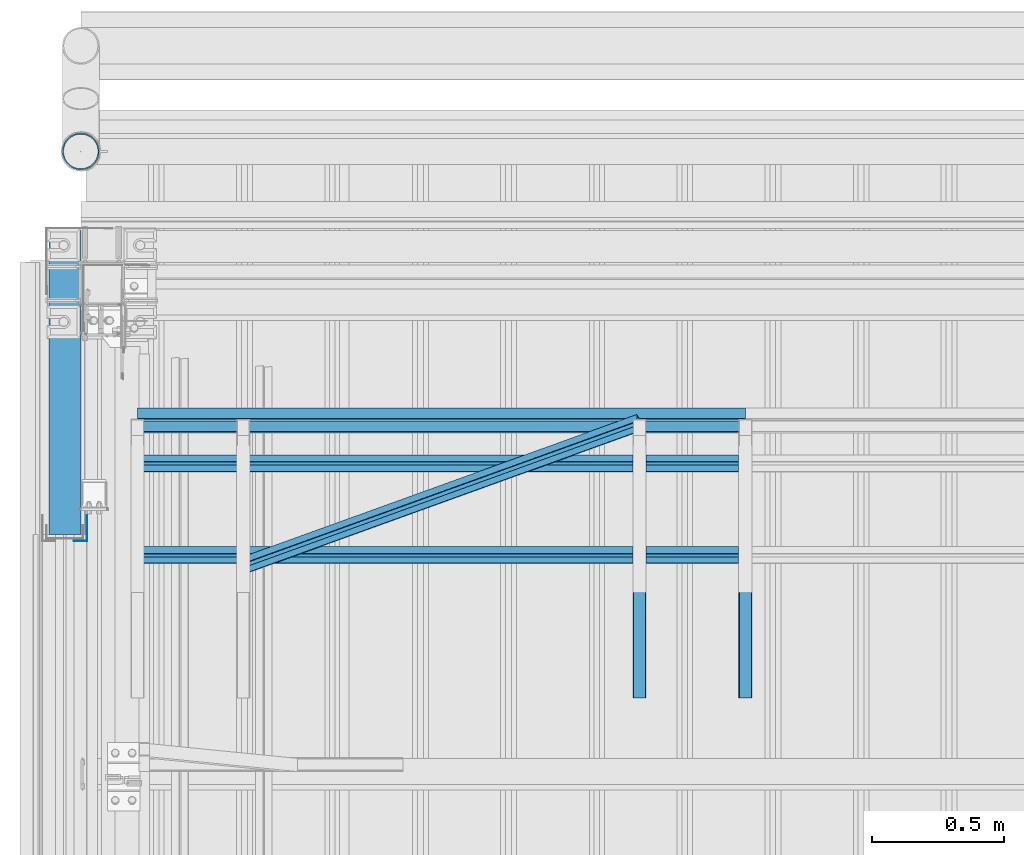
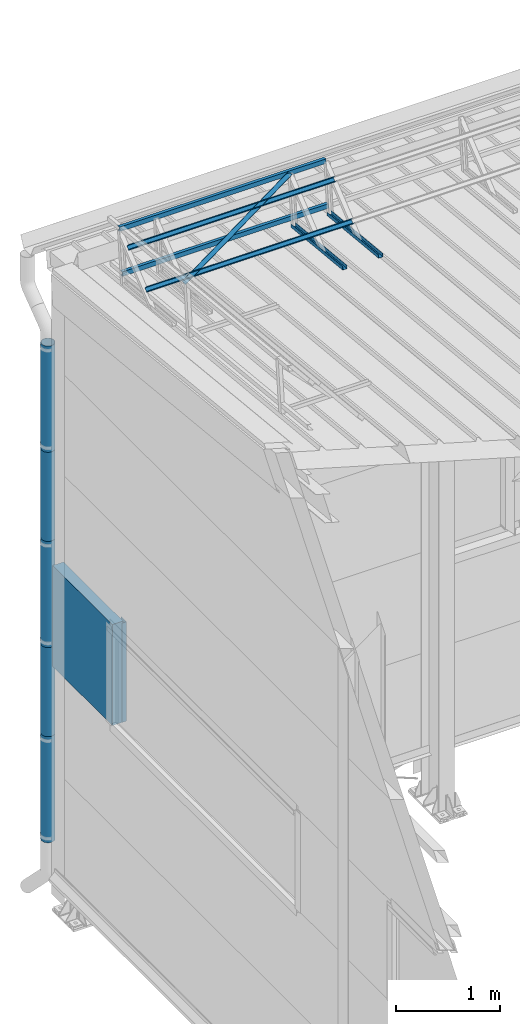
# One storey, part 51 of 709: 14 beams, 14 elements without a shape of their own.
"""IFC4 building model written with IfcOpenShell, lengths in millimetres."""

from ifc_helpers import new_model, si_unit, direction, frame, origin_with_axes, place, context, subcontext, project, spatial, line, indexed_curve, outline, extrude, material, element, aggregate, save


model = new_model("IFC4")

# Units and contexts
model_context = context("Model", 3, precision=0.2, world=origin_with_axes(), true_north=direction((0.0, 1.0)))
body_context = subcontext(model_context, "Body", "Model", "MODEL_VIEW")
ifc_project = project(units=[si_unit("LENGTHUNIT", "METRE", prefix="MILLI"), si_unit("AREAUNIT", "SQUARE_METRE"), si_unit("VOLUMEUNIT", "CUBIC_METRE"), si_unit("MASSUNIT", "GRAM", prefix="KILO"), si_unit("TIMEUNIT", "SECOND"), si_unit("PLANEANGLEUNIT", "RADIAN"), si_unit("SOLIDANGLEUNIT", "STERADIAN"), si_unit("THERMODYNAMICTEMPERATUREUNIT", "DEGREE_CELSIUS"), si_unit("LUMINOUSINTENSITYUNIT", "LUMEN")], contexts=[model_context])

# Site, building, storey
site_placement = place(None, origin_with_axes())
site = spatial("IfcSite", under=ifc_project, at=site_placement, CompositionType="ELEMENT")
building_placement = place(site_placement, origin_with_axes())
building = spatial("IfcBuilding", under=site, at=building_placement, Name="Undefined", CompositionType="ELEMENT")
storey_placement = place(building_placement, origin_with_axes())
storey = spatial("IfcBuildingStorey", under=building, at=storey_placement, Name="Undefined", CompositionType="ELEMENT", Elevation=0.0)

# Assembly, beam
assembly_1_placement = place(storey_placement, frame((2515.0, 21349.29926, 7565.33969), z_axis=(0.0, 0.099503719, 0.9950371902), x_axis=(0.0, -0.9950371902, 0.099503719)))
assembly_1 = element("IfcElementAssembly", 1, at=assembly_1_placement, inside=storey)
ifc_material_1 = material(Name="Steel_Undefined", Category="STEEL")
beam_1_placement = place(assembly_1_placement, origin_with_axes())
beam_1 = element("IfcBeam", 2, at=beam_1_placement, material=ifc_material_1, ObjectType="601", context=body_context, shape_type="SolidModel", body=[
    extrude(outline(indexed_curve([(-20.0, -25.0), (20.0, -25.0), (20.0, -22.5), (-17.5, -22.5), (-17.5, 22.5), (20.0, 22.5), (20.0, 25.0), (-20.0, 25.0)], segments=[line(1, 2, 3, 4, 5, 6, 7, 8, 1)])), frame((0.0, 0.0, 0.0), z_axis=(-1.0, 0.0, 0.0), x_axis=(0.0, 0.0, 1.0)), (0.0, 0.0, -1.0), 1000.0),
])
aggregate(assembly_1, [beam_1])

assembly_2_placement = place(storey_placement, frame((2115.0, 21349.29926, 7565.33969), z_axis=(0.0, 0.099503719, 0.9950371902), x_axis=(0.0, -0.9950371902, 0.099503719)))
assembly_2 = element("IfcElementAssembly", 3, at=assembly_2_placement, inside=storey)
beam_2_placement = place(assembly_2_placement, origin_with_axes())
beam_2 = element("IfcBeam", 4, at=beam_2_placement, material=ifc_material_1, ObjectType="601", context=body_context, shape_type="SolidModel", body=[
    extrude(outline(indexed_curve([(-20.0, -25.0), (20.0, -25.0), (20.0, -22.5), (-17.5, -22.5), (-17.5, 22.5), (20.0, 22.5), (20.0, 25.0), (-20.0, 25.0)], segments=[line(1, 2, 3, 4, 5, 6, 7, 8, 1)])), frame((0.0, 0.0, 0.0), z_axis=(-1.0, 0.0, 0.0), x_axis=(0.0, 0.0, 1.0)), (0.0, 0.0, -1.0), 1000.0),
])
aggregate(assembly_2, [beam_2])

assembly_3_placement = place(storey_placement, frame((2515.0, 21426.91216, 8140.47118), z_axis=(0.0, 0.9950371902, -0.099503719), x_axis=(-1.0, 0.0, 0.0)))
assembly_3 = element("IfcElementAssembly", 5, at=assembly_3_placement, inside=storey)
beam_3_placement = place(assembly_3_placement, origin_with_axes())
beam_3 = element("IfcBeam", 6, at=beam_3_placement, material=ifc_material_1, ObjectType="607", context=body_context, shape_type="SolidModel", body=[
    extrude(outline(indexed_curve([(-20.0, -25.0), (20.0, -25.0), (20.0, -22.5), (-17.5, -22.5), (-17.5, 22.5), (20.0, 22.5), (20.0, 25.0), (-20.0, 25.0)], segments=[line(1, 2, 3, 4, 5, 6, 7, 8, 1)])), frame((0.0, 0.0, 0.0), z_axis=(-1.0, 0.0, 0.0), x_axis=(0.0, 0.0, 1.0)), (0.0, 0.0, -1.0), 2300.0),
])
aggregate(assembly_3, [beam_3])

assembly_4_placement = place(storey_placement, frame((2515.0, 21377.1603, 7642.95259), z_axis=(0.0, 0.9950371902, -0.099503719), x_axis=(-1.0, 0.0, 0.0)))
assembly_4 = element("IfcElementAssembly", 7, at=assembly_4_placement, inside=storey)
beam_4_placement = place(assembly_4_placement, origin_with_axes())
beam_4 = element("IfcBeam", 8, at=beam_4_placement, material=ifc_material_1, ObjectType="607", context=body_context, shape_type="SolidModel", body=[
    extrude(outline(indexed_curve([(-20.0, -25.0), (20.0, -25.0), (20.0, -22.5), (-17.5, -22.5), (-17.5, 22.5), (20.0, 22.5), (20.0, 25.0), (-20.0, 25.0)], segments=[line(1, 2, 3, 4, 5, 6, 7, 8, 1)])), frame((0.0, 0.0, 0.0), z_axis=(-1.0, 0.0, 0.0), x_axis=(0.0, 0.0, 1.0)), (0.0, 0.0, -1.0), 2300.0),
])
aggregate(assembly_4, [beam_4])

assembly_5_placement = place(storey_placement, frame((2515.0, 21239.5552, 8031.29285), z_axis=(0.0, -0.6332377902, 0.7739572992), x_axis=(-1.0, 0.0, 0.0)))
assembly_5 = element("IfcElementAssembly", 9, at=assembly_5_placement, inside=storey)
beam_5_placement = place(assembly_5_placement, origin_with_axes())
beam_5 = element("IfcBeam", 10, at=beam_5_placement, material=ifc_material_1, ObjectType="607", context=body_context, shape_type="SolidModel", body=[
    extrude(outline(indexed_curve([(-20.0, -25.0), (20.0, -25.0), (20.0, -22.5), (-17.5, -22.5), (-17.5, 22.5), (20.0, 22.5), (20.0, 25.0), (-20.0, 25.0)], segments=[line(1, 2, 3, 4, 5, 6, 7, 8, 1)])), frame((0.0, 0.0, 0.0), z_axis=(-1.0, 0.0, 0.0), x_axis=(0.0, 0.0, 1.0)), (0.0, 0.0, -1.0), 2300.0),
])
aggregate(assembly_5, [beam_5])

assembly_6_placement = place(storey_placement, frame((2515.0, 20892.41357, 7747.26788), z_axis=(0.0, -0.6332377902, 0.7739572992), x_axis=(-1.0, 0.0, 0.0)))
assembly_6 = element("IfcElementAssembly", 11, at=assembly_6_placement, inside=storey)
beam_6_placement = place(assembly_6_placement, origin_with_axes())
beam_6 = element("IfcBeam", 12, at=beam_6_placement, material=ifc_material_1, ObjectType="607", context=body_context, shape_type="SolidModel", body=[
    extrude(outline(indexed_curve([(-20.0, -25.0), (20.0, -25.0), (20.0, -22.5), (-17.5, -22.5), (-17.5, 22.5), (20.0, 22.5), (20.0, 25.0), (-20.0, 25.0)], segments=[line(1, 2, 3, 4, 5, 6, 7, 8, 1)])), frame((0.0, 0.0, 0.0), z_axis=(-1.0, 0.0, 0.0), x_axis=(0.0, 0.0, 1.0)), (0.0, 0.0, -1.0), 2300.0),
])
aggregate(assembly_6, [beam_6])

assembly_7_placement = place(storey_placement, frame((2115.0, 21394.34666, 8157.9404), z_axis=(0.0, -0.6332377902, 0.7739572992), x_axis=(-0.9061831398, -0.3272952929, -0.2677870579)))
assembly_7 = element("IfcElementAssembly", 13, at=assembly_7_placement, inside=storey)
beam_7_placement = place(assembly_7_placement, origin_with_axes())
beam_7 = element("IfcBeam", 14, at=beam_7_placement, material=ifc_material_1, ObjectType="605", context=body_context, shape_type="SolidModel", body=[
    extrude(outline(indexed_curve([(-20.0, -25.0), (20.0, -25.0), (20.0, -22.5), (-17.5, -22.5), (-17.5, 22.5), (20.0, 22.5), (20.0, 25.0), (-20.0, 25.0)], segments=[line(1, 2, 3, 4, 5, 6, 7, 8, 1)])), frame((0.0, 0.0, 0.0), z_axis=(-1.0, 0.0, 0.0), x_axis=(0.0, 0.0, 1.0)), (0.0, 0.0, -1.0), 1655.29454),
])
aggregate(assembly_7, [beam_7])

assembly_8_placement = place(storey_placement, frame((0.0, 22420.0, 6276.92297), z_axis=(0.0, -1.0, 0.0), x_axis=(0.0, 0.0, -1.0)))
assembly_8 = element("IfcElementAssembly", 15, at=assembly_8_placement, inside=storey)
beam_8_placement = place(assembly_8_placement, origin_with_axes())
beam_8 = element("IfcBeam", 16, at=beam_8_placement, material=ifc_material_1, ObjectType="614", context=body_context, shape_type="SolidModel", body=[
    extrude(outline(indexed_curve([(70.0, 0.0), (69.61653, 7.31699), (68.47033, 14.55382), (66.57396, 21.63119), (63.94818, 28.47157), (60.62178, 35.0), (56.63119, 41.14497), (52.02014, 46.83914), (46.83914, 52.02014), (41.14497, 56.63119), (35.0, 60.62178), (28.47157, 63.94818), (21.63119, 66.57396), (14.55382, 68.47033), (7.31699, 69.61653), (0.0, 70.0), (-7.31699, 69.61653), (-14.55382, 68.47033), (-21.63119, 66.57396), (-28.47157, 63.94818), (-35.0, 60.62178), (-41.14497, 56.63119), (-46.83914, 52.02014), (-52.02014, 46.83914), (-56.63119, 41.14497), (-60.62178, 35.0), (-63.94818, 28.47157), (-66.57396, 21.63119), (-68.47033, 14.55382), (-69.61653, 7.31699), (-70.0, 0.0), (-69.61653, -7.31699), (-68.47033, -14.55382), (-66.57396, -21.63119), (-63.94818, -28.47157), (-60.62178, -35.0), (-56.63119, -41.14497), (-52.02014, -46.83914), (-46.83914, -52.02014), (-41.14497, -56.63119), (-35.0, -60.62178), (-28.47157, -63.94818), (-21.63119, -66.57396), (-14.55382, -68.47033), (-7.31699, -69.61653), (0.0, -70.0), (7.31699, -69.61653), (14.55382, -68.47033), (21.63119, -66.57396), (28.47157, -63.94818), (35.0, -60.62178), (41.14497, -56.63119), (46.83914, -52.02014), (52.02014, -46.83914), (56.63119, -41.14497), (60.62178, -35.0), (63.94818, -28.47157), (66.57396, -21.63119), (68.47033, -14.55382), (69.61653, -7.31699)], segments=[line(1, 2, 3, 4, 5, 6, 7, 8, 9, 10, 11, 12, 13, 14, 15, 16, 17, 18, 19, 20, 21, 22, 23, 24, 25, 26, 27, 28, 29, 30, 31, 32, 33, 34, 35, 36, 37, 38, 39, 40, 41, 42, 43, 44, 45, 46, 47, 48, 49, 50, 51, 52, 53, 54, 55, 56, 57, 58, 59, 60, 1)]), holes=[indexed_curve([(65.0, 0.0), (64.64392, -6.79435), (63.57959, -13.51426), (61.81867, -20.0861), (59.38045, -26.43788), (56.29165, -32.5), (52.5861, -38.20604), (48.30441, -43.49349), (43.49349, -48.30441), (38.20604, -52.5861), (32.5, -56.29165), (26.43788, -59.38045), (20.0861, -61.81867), (13.51426, -63.57959), (6.79435, -64.64392), (0.0, -65.0), (-6.79435, -64.64392), (-13.51426, -63.57959), (-20.0861, -61.81867), (-26.43788, -59.38045), (-32.5, -56.29165), (-38.20604, -52.5861), (-43.49349, -48.30441), (-48.30441, -43.49349), (-52.5861, -38.20604), (-56.29165, -32.5), (-59.38045, -26.43788), (-61.81867, -20.0861), (-63.57959, -13.51426), (-64.64392, -6.79435), (-65.0, 0.0), (-64.64392, 6.79435), (-63.57959, 13.51426), (-61.81867, 20.0861), (-59.38045, 26.43788), (-56.29165, 32.5), (-52.5861, 38.20604), (-48.30441, 43.49349), (-43.49349, 48.30441), (-38.20604, 52.5861), (-32.5, 56.29165), (-26.43788, 59.38045), (-20.0861, 61.81867), (-13.51426, 63.57959), (-6.79435, 64.64392), (0.0, 65.0), (6.79435, 64.64392), (13.51426, 63.57959), (20.0861, 61.81867), (26.43788, 59.38045), (32.5, 56.29165), (38.20604, 52.5861), (43.49349, 48.30441), (48.30441, 43.49349), (52.5861, 38.20604), (56.29165, 32.5), (59.38045, 26.43788), (61.81867, 20.0861), (63.57959, 13.51426), (64.64392, 6.79435)], segments=[line(1, 2, 3, 4, 5, 6, 7, 8, 9, 10, 11, 12, 13, 14, 15, 16, 17, 18, 19, 20, 21, 22, 23, 24, 25, 26, 27, 28, 29, 30, 31, 32, 33, 34, 35, 36, 37, 38, 39, 40, 41, 42, 43, 44, 45, 46, 47, 48, 49, 50, 51, 52, 53, 54, 55, 56, 57, 58, 59, 60, 1)])]), frame((0.0, 0.0, 0.0), z_axis=(-1.0, 0.0, 0.0), x_axis=(0.0, 0.0, 1.0)), (0.0, 0.0, -1.0), 1250.0),
])
aggregate(assembly_8, [beam_8])

assembly_9_placement = place(storey_placement, frame((0.0, 22420.0, 5126.92297), z_axis=(0.0, -1.0, 0.0), x_axis=(0.0, 0.0, -1.0)))
assembly_9 = element("IfcElementAssembly", 17, at=assembly_9_placement, inside=storey)
beam_9_placement = place(assembly_9_placement, origin_with_axes())
beam_9 = element("IfcBeam", 18, at=beam_9_placement, material=ifc_material_1, ObjectType="614", context=body_context, shape_type="SolidModel", body=[
    extrude(outline(indexed_curve([(70.0, 0.0), (69.61653, 7.31699), (68.47033, 14.55382), (66.57396, 21.63119), (63.94818, 28.47157), (60.62178, 35.0), (56.63119, 41.14497), (52.02014, 46.83914), (46.83914, 52.02014), (41.14497, 56.63119), (35.0, 60.62178), (28.47157, 63.94818), (21.63119, 66.57396), (14.55382, 68.47033), (7.31699, 69.61653), (0.0, 70.0), (-7.31699, 69.61653), (-14.55382, 68.47033), (-21.63119, 66.57396), (-28.47157, 63.94818), (-35.0, 60.62178), (-41.14497, 56.63119), (-46.83914, 52.02014), (-52.02014, 46.83914), (-56.63119, 41.14497), (-60.62178, 35.0), (-63.94818, 28.47157), (-66.57396, 21.63119), (-68.47033, 14.55382), (-69.61653, 7.31699), (-70.0, 0.0), (-69.61653, -7.31699), (-68.47033, -14.55382), (-66.57396, -21.63119), (-63.94818, -28.47157), (-60.62178, -35.0), (-56.63119, -41.14497), (-52.02014, -46.83914), (-46.83914, -52.02014), (-41.14497, -56.63119), (-35.0, -60.62178), (-28.47157, -63.94818), (-21.63119, -66.57396), (-14.55382, -68.47033), (-7.31699, -69.61653), (0.0, -70.0), (7.31699, -69.61653), (14.55382, -68.47033), (21.63119, -66.57396), (28.47157, -63.94818), (35.0, -60.62178), (41.14497, -56.63119), (46.83914, -52.02014), (52.02014, -46.83914), (56.63119, -41.14497), (60.62178, -35.0), (63.94818, -28.47157), (66.57396, -21.63119), (68.47033, -14.55382), (69.61653, -7.31699)], segments=[line(1, 2, 3, 4, 5, 6, 7, 8, 9, 10, 11, 12, 13, 14, 15, 16, 17, 18, 19, 20, 21, 22, 23, 24, 25, 26, 27, 28, 29, 30, 31, 32, 33, 34, 35, 36, 37, 38, 39, 40, 41, 42, 43, 44, 45, 46, 47, 48, 49, 50, 51, 52, 53, 54, 55, 56, 57, 58, 59, 60, 1)]), holes=[indexed_curve([(65.0, 0.0), (64.64392, -6.79435), (63.57959, -13.51426), (61.81867, -20.0861), (59.38045, -26.43788), (56.29165, -32.5), (52.5861, -38.20604), (48.30441, -43.49349), (43.49349, -48.30441), (38.20604, -52.5861), (32.5, -56.29165), (26.43788, -59.38045), (20.0861, -61.81867), (13.51426, -63.57959), (6.79435, -64.64392), (0.0, -65.0), (-6.79435, -64.64392), (-13.51426, -63.57959), (-20.0861, -61.81867), (-26.43788, -59.38045), (-32.5, -56.29165), (-38.20604, -52.5861), (-43.49349, -48.30441), (-48.30441, -43.49349), (-52.5861, -38.20604), (-56.29165, -32.5), (-59.38045, -26.43788), (-61.81867, -20.0861), (-63.57959, -13.51426), (-64.64392, -6.79435), (-65.0, 0.0), (-64.64392, 6.79435), (-63.57959, 13.51426), (-61.81867, 20.0861), (-59.38045, 26.43788), (-56.29165, 32.5), (-52.5861, 38.20604), (-48.30441, 43.49349), (-43.49349, 48.30441), (-38.20604, 52.5861), (-32.5, 56.29165), (-26.43788, 59.38045), (-20.0861, 61.81867), (-13.51426, 63.57959), (-6.79435, 64.64392), (0.0, 65.0), (6.79435, 64.64392), (13.51426, 63.57959), (20.0861, 61.81867), (26.43788, 59.38045), (32.5, 56.29165), (38.20604, 52.5861), (43.49349, 48.30441), (48.30441, 43.49349), (52.5861, 38.20604), (56.29165, 32.5), (59.38045, 26.43788), (61.81867, 20.0861), (63.57959, 13.51426), (64.64392, 6.79435)], segments=[line(1, 2, 3, 4, 5, 6, 7, 8, 9, 10, 11, 12, 13, 14, 15, 16, 17, 18, 19, 20, 21, 22, 23, 24, 25, 26, 27, 28, 29, 30, 31, 32, 33, 34, 35, 36, 37, 38, 39, 40, 41, 42, 43, 44, 45, 46, 47, 48, 49, 50, 51, 52, 53, 54, 55, 56, 57, 58, 59, 60, 1)])]), frame((0.0, 0.0, 0.0), z_axis=(-1.0, 0.0, 0.0), x_axis=(0.0, 0.0, 1.0)), (0.0, 0.0, -1.0), 1250.0),
])
aggregate(assembly_9, [beam_9])

assembly_10_placement = place(storey_placement, frame((0.0, 22420.0, 3976.92297), z_axis=(0.0, -1.0, 0.0), x_axis=(0.0, 0.0, -1.0)))
assembly_10 = element("IfcElementAssembly", 19, at=assembly_10_placement, inside=storey)
beam_10_placement = place(assembly_10_placement, origin_with_axes())
beam_10 = element("IfcBeam", 20, at=beam_10_placement, material=ifc_material_1, ObjectType="614", context=body_context, shape_type="SolidModel", body=[
    extrude(outline(indexed_curve([(70.0, 0.0), (69.61653, 7.31699), (68.47033, 14.55382), (66.57396, 21.63119), (63.94818, 28.47157), (60.62178, 35.0), (56.63119, 41.14497), (52.02014, 46.83914), (46.83914, 52.02014), (41.14497, 56.63119), (35.0, 60.62178), (28.47157, 63.94818), (21.63119, 66.57396), (14.55382, 68.47033), (7.31699, 69.61653), (0.0, 70.0), (-7.31699, 69.61653), (-14.55382, 68.47033), (-21.63119, 66.57396), (-28.47157, 63.94818), (-35.0, 60.62178), (-41.14497, 56.63119), (-46.83914, 52.02014), (-52.02014, 46.83914), (-56.63119, 41.14497), (-60.62178, 35.0), (-63.94818, 28.47157), (-66.57396, 21.63119), (-68.47033, 14.55382), (-69.61653, 7.31699), (-70.0, 0.0), (-69.61653, -7.31699), (-68.47033, -14.55382), (-66.57396, -21.63119), (-63.94818, -28.47157), (-60.62178, -35.0), (-56.63119, -41.14497), (-52.02014, -46.83914), (-46.83914, -52.02014), (-41.14497, -56.63119), (-35.0, -60.62178), (-28.47157, -63.94818), (-21.63119, -66.57396), (-14.55382, -68.47033), (-7.31699, -69.61653), (0.0, -70.0), (7.31699, -69.61653), (14.55382, -68.47033), (21.63119, -66.57396), (28.47157, -63.94818), (35.0, -60.62178), (41.14497, -56.63119), (46.83914, -52.02014), (52.02014, -46.83914), (56.63119, -41.14497), (60.62178, -35.0), (63.94818, -28.47157), (66.57396, -21.63119), (68.47033, -14.55382), (69.61653, -7.31699)], segments=[line(1, 2, 3, 4, 5, 6, 7, 8, 9, 10, 11, 12, 13, 14, 15, 16, 17, 18, 19, 20, 21, 22, 23, 24, 25, 26, 27, 28, 29, 30, 31, 32, 33, 34, 35, 36, 37, 38, 39, 40, 41, 42, 43, 44, 45, 46, 47, 48, 49, 50, 51, 52, 53, 54, 55, 56, 57, 58, 59, 60, 1)]), holes=[indexed_curve([(65.0, 0.0), (64.64392, -6.79435), (63.57959, -13.51426), (61.81867, -20.0861), (59.38045, -26.43788), (56.29165, -32.5), (52.5861, -38.20604), (48.30441, -43.49349), (43.49349, -48.30441), (38.20604, -52.5861), (32.5, -56.29165), (26.43788, -59.38045), (20.0861, -61.81867), (13.51426, -63.57959), (6.79435, -64.64392), (0.0, -65.0), (-6.79435, -64.64392), (-13.51426, -63.57959), (-20.0861, -61.81867), (-26.43788, -59.38045), (-32.5, -56.29165), (-38.20604, -52.5861), (-43.49349, -48.30441), (-48.30441, -43.49349), (-52.5861, -38.20604), (-56.29165, -32.5), (-59.38045, -26.43788), (-61.81867, -20.0861), (-63.57959, -13.51426), (-64.64392, -6.79435), (-65.0, 0.0), (-64.64392, 6.79435), (-63.57959, 13.51426), (-61.81867, 20.0861), (-59.38045, 26.43788), (-56.29165, 32.5), (-52.5861, 38.20604), (-48.30441, 43.49349), (-43.49349, 48.30441), (-38.20604, 52.5861), (-32.5, 56.29165), (-26.43788, 59.38045), (-20.0861, 61.81867), (-13.51426, 63.57959), (-6.79435, 64.64392), (0.0, 65.0), (6.79435, 64.64392), (13.51426, 63.57959), (20.0861, 61.81867), (26.43788, 59.38045), (32.5, 56.29165), (38.20604, 52.5861), (43.49349, 48.30441), (48.30441, 43.49349), (52.5861, 38.20604), (56.29165, 32.5), (59.38045, 26.43788), (61.81867, 20.0861), (63.57959, 13.51426), (64.64392, 6.79435)], segments=[line(1, 2, 3, 4, 5, 6, 7, 8, 9, 10, 11, 12, 13, 14, 15, 16, 17, 18, 19, 20, 21, 22, 23, 24, 25, 26, 27, 28, 29, 30, 31, 32, 33, 34, 35, 36, 37, 38, 39, 40, 41, 42, 43, 44, 45, 46, 47, 48, 49, 50, 51, 52, 53, 54, 55, 56, 57, 58, 59, 60, 1)])]), frame((0.0, 0.0, 0.0), z_axis=(-1.0, 0.0, 0.0), x_axis=(0.0, 0.0, 1.0)), (0.0, 0.0, -1.0), 1250.0),
])
aggregate(assembly_10, [beam_10])

assembly_11_placement = place(storey_placement, frame((0.0, 22420.0, 2826.92297), z_axis=(0.0, -1.0, 0.0), x_axis=(0.0, 0.0, -1.0)))
assembly_11 = element("IfcElementAssembly", 21, at=assembly_11_placement, inside=storey)
beam_11_placement = place(assembly_11_placement, origin_with_axes())
beam_11 = element("IfcBeam", 22, at=beam_11_placement, material=ifc_material_1, ObjectType="614", context=body_context, shape_type="SolidModel", body=[
    extrude(outline(indexed_curve([(70.0, 0.0), (69.61653, 7.31699), (68.47033, 14.55382), (66.57396, 21.63119), (63.94818, 28.47157), (60.62178, 35.0), (56.63119, 41.14497), (52.02014, 46.83914), (46.83914, 52.02014), (41.14497, 56.63119), (35.0, 60.62178), (28.47157, 63.94818), (21.63119, 66.57396), (14.55382, 68.47033), (7.31699, 69.61653), (0.0, 70.0), (-7.31699, 69.61653), (-14.55382, 68.47033), (-21.63119, 66.57396), (-28.47157, 63.94818), (-35.0, 60.62178), (-41.14497, 56.63119), (-46.83914, 52.02014), (-52.02014, 46.83914), (-56.63119, 41.14497), (-60.62178, 35.0), (-63.94818, 28.47157), (-66.57396, 21.63119), (-68.47033, 14.55382), (-69.61653, 7.31699), (-70.0, 0.0), (-69.61653, -7.31699), (-68.47033, -14.55382), (-66.57396, -21.63119), (-63.94818, -28.47157), (-60.62178, -35.0), (-56.63119, -41.14497), (-52.02014, -46.83914), (-46.83914, -52.02014), (-41.14497, -56.63119), (-35.0, -60.62178), (-28.47157, -63.94818), (-21.63119, -66.57396), (-14.55382, -68.47033), (-7.31699, -69.61653), (0.0, -70.0), (7.31699, -69.61653), (14.55382, -68.47033), (21.63119, -66.57396), (28.47157, -63.94818), (35.0, -60.62178), (41.14497, -56.63119), (46.83914, -52.02014), (52.02014, -46.83914), (56.63119, -41.14497), (60.62178, -35.0), (63.94818, -28.47157), (66.57396, -21.63119), (68.47033, -14.55382), (69.61653, -7.31699)], segments=[line(1, 2, 3, 4, 5, 6, 7, 8, 9, 10, 11, 12, 13, 14, 15, 16, 17, 18, 19, 20, 21, 22, 23, 24, 25, 26, 27, 28, 29, 30, 31, 32, 33, 34, 35, 36, 37, 38, 39, 40, 41, 42, 43, 44, 45, 46, 47, 48, 49, 50, 51, 52, 53, 54, 55, 56, 57, 58, 59, 60, 1)]), holes=[indexed_curve([(65.0, 0.0), (64.64392, -6.79435), (63.57959, -13.51426), (61.81867, -20.0861), (59.38045, -26.43788), (56.29165, -32.5), (52.5861, -38.20604), (48.30441, -43.49349), (43.49349, -48.30441), (38.20604, -52.5861), (32.5, -56.29165), (26.43788, -59.38045), (20.0861, -61.81867), (13.51426, -63.57959), (6.79435, -64.64392), (0.0, -65.0), (-6.79435, -64.64392), (-13.51426, -63.57959), (-20.0861, -61.81867), (-26.43788, -59.38045), (-32.5, -56.29165), (-38.20604, -52.5861), (-43.49349, -48.30441), (-48.30441, -43.49349), (-52.5861, -38.20604), (-56.29165, -32.5), (-59.38045, -26.43788), (-61.81867, -20.0861), (-63.57959, -13.51426), (-64.64392, -6.79435), (-65.0, 0.0), (-64.64392, 6.79435), (-63.57959, 13.51426), (-61.81867, 20.0861), (-59.38045, 26.43788), (-56.29165, 32.5), (-52.5861, 38.20604), (-48.30441, 43.49349), (-43.49349, 48.30441), (-38.20604, 52.5861), (-32.5, 56.29165), (-26.43788, 59.38045), (-20.0861, 61.81867), (-13.51426, 63.57959), (-6.79435, 64.64392), (0.0, 65.0), (6.79435, 64.64392), (13.51426, 63.57959), (20.0861, 61.81867), (26.43788, 59.38045), (32.5, 56.29165), (38.20604, 52.5861), (43.49349, 48.30441), (48.30441, 43.49349), (52.5861, 38.20604), (56.29165, 32.5), (59.38045, 26.43788), (61.81867, 20.0861), (63.57959, 13.51426), (64.64392, 6.79435)], segments=[line(1, 2, 3, 4, 5, 6, 7, 8, 9, 10, 11, 12, 13, 14, 15, 16, 17, 18, 19, 20, 21, 22, 23, 24, 25, 26, 27, 28, 29, 30, 31, 32, 33, 34, 35, 36, 37, 38, 39, 40, 41, 42, 43, 44, 45, 46, 47, 48, 49, 50, 51, 52, 53, 54, 55, 56, 57, 58, 59, 60, 1)])]), frame((0.0, 0.0, 0.0), z_axis=(-1.0, 0.0, 0.0), x_axis=(0.0, 0.0, 1.0)), (0.0, 0.0, -1.0), 1250.0),
])
aggregate(assembly_11, [beam_11])

assembly_12_placement = place(storey_placement, frame((0.0, 22420.0, 1676.92297), z_axis=(0.0, -1.0, 0.0), x_axis=(0.0, 0.0, -1.0)))
assembly_12 = element("IfcElementAssembly", 23, at=assembly_12_placement, inside=storey)
beam_12_placement = place(assembly_12_placement, origin_with_axes())
beam_12 = element("IfcBeam", 24, at=beam_12_placement, material=ifc_material_1, ObjectType="614", context=body_context, shape_type="SolidModel", body=[
    extrude(outline(indexed_curve([(70.0, 0.0), (69.61653, 7.31699), (68.47033, 14.55382), (66.57396, 21.63119), (63.94818, 28.47157), (60.62178, 35.0), (56.63119, 41.14497), (52.02014, 46.83914), (46.83914, 52.02014), (41.14497, 56.63119), (35.0, 60.62178), (28.47157, 63.94818), (21.63119, 66.57396), (14.55382, 68.47033), (7.31699, 69.61653), (0.0, 70.0), (-7.31699, 69.61653), (-14.55382, 68.47033), (-21.63119, 66.57396), (-28.47157, 63.94818), (-35.0, 60.62178), (-41.14497, 56.63119), (-46.83914, 52.02014), (-52.02014, 46.83914), (-56.63119, 41.14497), (-60.62178, 35.0), (-63.94818, 28.47157), (-66.57396, 21.63119), (-68.47033, 14.55382), (-69.61653, 7.31699), (-70.0, 0.0), (-69.61653, -7.31699), (-68.47033, -14.55382), (-66.57396, -21.63119), (-63.94818, -28.47157), (-60.62178, -35.0), (-56.63119, -41.14497), (-52.02014, -46.83914), (-46.83914, -52.02014), (-41.14497, -56.63119), (-35.0, -60.62178), (-28.47157, -63.94818), (-21.63119, -66.57396), (-14.55382, -68.47033), (-7.31699, -69.61653), (0.0, -70.0), (7.31699, -69.61653), (14.55382, -68.47033), (21.63119, -66.57396), (28.47157, -63.94818), (35.0, -60.62178), (41.14497, -56.63119), (46.83914, -52.02014), (52.02014, -46.83914), (56.63119, -41.14497), (60.62178, -35.0), (63.94818, -28.47157), (66.57396, -21.63119), (68.47033, -14.55382), (69.61653, -7.31699)], segments=[line(1, 2, 3, 4, 5, 6, 7, 8, 9, 10, 11, 12, 13, 14, 15, 16, 17, 18, 19, 20, 21, 22, 23, 24, 25, 26, 27, 28, 29, 30, 31, 32, 33, 34, 35, 36, 37, 38, 39, 40, 41, 42, 43, 44, 45, 46, 47, 48, 49, 50, 51, 52, 53, 54, 55, 56, 57, 58, 59, 60, 1)]), holes=[indexed_curve([(65.0, 0.0), (64.64392, -6.79435), (63.57959, -13.51426), (61.81867, -20.0861), (59.38045, -26.43788), (56.29165, -32.5), (52.5861, -38.20604), (48.30441, -43.49349), (43.49349, -48.30441), (38.20604, -52.5861), (32.5, -56.29165), (26.43788, -59.38045), (20.0861, -61.81867), (13.51426, -63.57959), (6.79435, -64.64392), (0.0, -65.0), (-6.79435, -64.64392), (-13.51426, -63.57959), (-20.0861, -61.81867), (-26.43788, -59.38045), (-32.5, -56.29165), (-38.20604, -52.5861), (-43.49349, -48.30441), (-48.30441, -43.49349), (-52.5861, -38.20604), (-56.29165, -32.5), (-59.38045, -26.43788), (-61.81867, -20.0861), (-63.57959, -13.51426), (-64.64392, -6.79435), (-65.0, 0.0), (-64.64392, 6.79435), (-63.57959, 13.51426), (-61.81867, 20.0861), (-59.38045, 26.43788), (-56.29165, 32.5), (-52.5861, 38.20604), (-48.30441, 43.49349), (-43.49349, 48.30441), (-38.20604, 52.5861), (-32.5, 56.29165), (-26.43788, 59.38045), (-20.0861, 61.81867), (-13.51426, 63.57959), (-6.79435, 64.64392), (0.0, 65.0), (6.79435, 64.64392), (13.51426, 63.57959), (20.0861, 61.81867), (26.43788, 59.38045), (32.5, 56.29165), (38.20604, 52.5861), (43.49349, 48.30441), (48.30441, 43.49349), (52.5861, 38.20604), (56.29165, 32.5), (59.38045, 26.43788), (61.81867, 20.0861), (63.57959, 13.51426), (64.64392, 6.79435)], segments=[line(1, 2, 3, 4, 5, 6, 7, 8, 9, 10, 11, 12, 13, 14, 15, 16, 17, 18, 19, 20, 21, 22, 23, 24, 25, 26, 27, 28, 29, 30, 31, 32, 33, 34, 35, 36, 37, 38, 39, 40, 41, 42, 43, 44, 45, 46, 47, 48, 49, 50, 51, 52, 53, 54, 55, 56, 57, 58, 59, 60, 1)])]), frame((0.0, 0.0, 0.0), z_axis=(-1.0, 0.0, 0.0), x_axis=(0.0, 0.0, 1.0)), (0.0, 0.0, -1.0), 1250.0),
])
aggregate(assembly_12, [beam_12])

assembly_13_placement = place(storey_placement, frame((-60.0, 20970.0, 3275.0), z_axis=(0.0, 0.0, -1.0), x_axis=(0.0, 1.0, 0.0)))
assembly_13 = element("IfcElementAssembly", 25, at=assembly_13_placement, inside=storey)
ifc_material_2 = material(Name="Insulation", Category="Insulation")
beam_13_placement = place(assembly_13_placement, origin_with_axes())
beam_13 = element("IfcBeam", 26, at=beam_13_placement, material=ifc_material_2, ObjectType="P-141", context=body_context, shape_type="SolidModel", body=[
    extrude(outline(indexed_curve([(-595.0, -60.0), (595.0, -60.0), (595.0, 60.0), (-595.0, 60.0)], segments=[line(1, 2, 3, 4, 1)])), frame((0.0, 0.0, 0.0), z_axis=(-1.0, 0.0, 0.0), x_axis=(0.0, 0.0, 1.0)), (0.0, 0.0, -1.0), 1150.0),
])
aggregate(assembly_13, [beam_13])

assembly_14_placement = place(storey_placement, frame((-1.0, 20945.0, 3870.0), z_axis=(1.0, 0.0, 0.0), x_axis=(0.0, 0.0, -1.0)))
assembly_14 = element("IfcElementAssembly", 27, at=assembly_14_placement, inside=storey)
beam_14_placement = place(assembly_14_placement, origin_with_axes())
beam_14 = element("IfcBeam", 28, at=beam_14_placement, material=ifc_material_1, context=body_context, shape_type="SolidModel", body=[
    extrude(outline(indexed_curve([(-25.0, -1.0), (25.0, -1.0), (25.0, 99.0), (23.0, 99.0), (23.0, 1.0), (-25.0, 1.0)], segments=[line(1, 2, 3, 4, 5, 6, 1)])), frame((0.0, 0.0, 0.0), z_axis=(-1.0, 0.0, 0.0), x_axis=(0.0, 0.0, 1.0)), (0.0, 0.0, -1.0), 1170.0),
])
aggregate(assembly_14, [beam_14])

save(model, "model.ifc")
